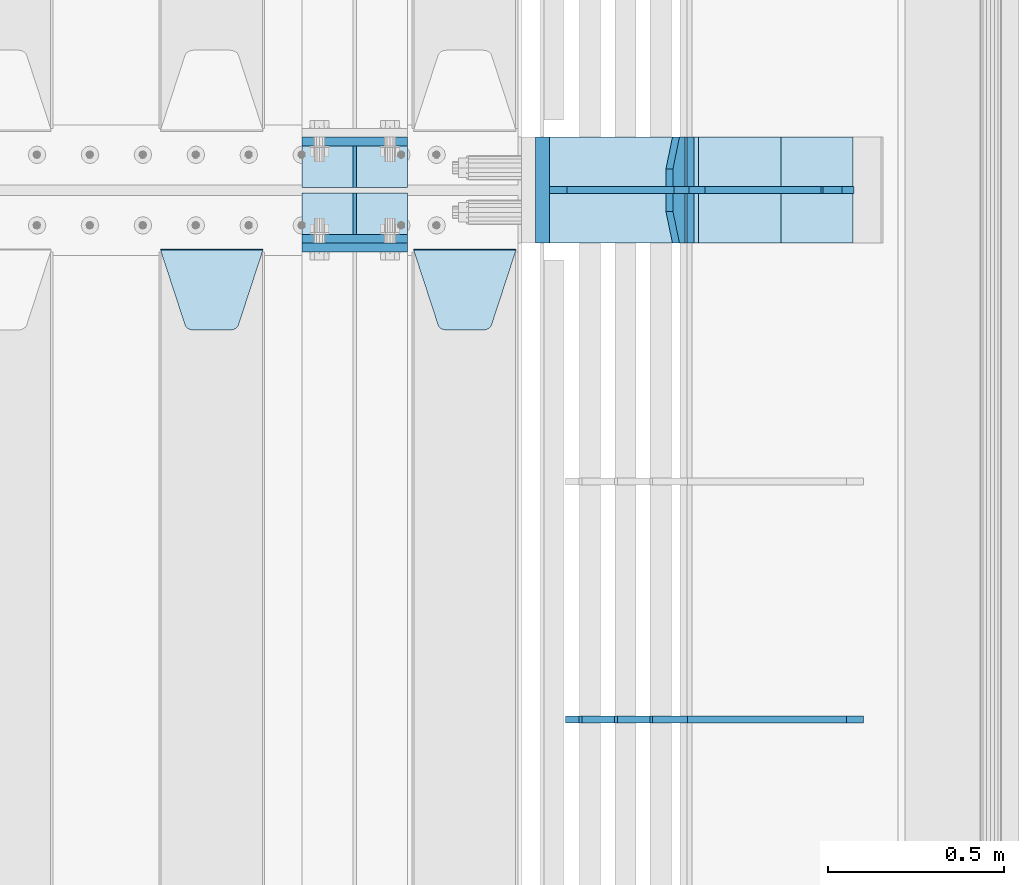
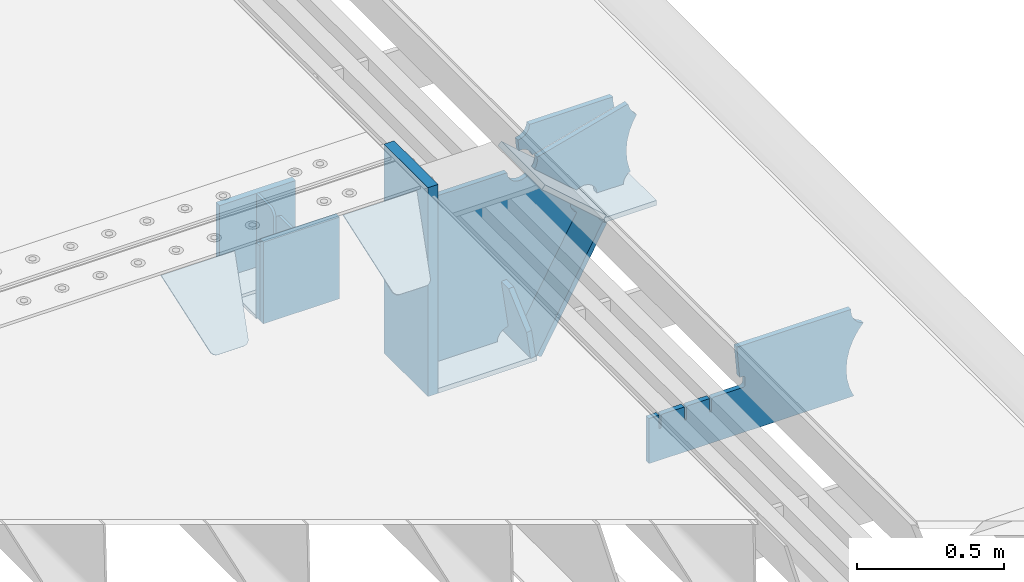
# One storey, part 203 of 240: 19 plates.
"""IFC2X3 building model written with IfcOpenShell, lengths in millimetres."""

from ifc_helpers import new_model, si_unit, frame, origin_with_axes, place, context, subcontext, project, spatial, faceted_brep, material, type_object, element, save


model = new_model("IFC2X3")

# Units and contexts
model_context = context("Model", 3, precision=1e-05, world=origin_with_axes())
body_context = subcontext(model_context, "Body", "Model", "MODEL_VIEW")
ifc_project = project(units=[si_unit("LENGTHUNIT", "METRE", prefix="MILLI"), si_unit("AREAUNIT", "SQUARE_METRE"), si_unit("VOLUMEUNIT", "CUBIC_METRE"), si_unit("MASSUNIT", "GRAM", prefix="KILO"), si_unit("TIMEUNIT", "SECOND"), si_unit("PLANEANGLEUNIT", "RADIAN"), si_unit("SOLIDANGLEUNIT", "STERADIAN"), si_unit("THERMODYNAMICTEMPERATUREUNIT", "DEGREE_CELSIUS"), si_unit("LUMINOUSINTENSITYUNIT", "LUMEN")], contexts=[model_context])

# Site, building, storey
site_placement = place(None, origin_with_axes())
site = spatial("IfcSite", under=ifc_project, at=site_placement, CompositionType="ELEMENT")
building_placement = place(site_placement, origin_with_axes())
building = spatial("IfcBuilding", under=site, at=building_placement, Name="Standard", CompositionType="ELEMENT")
storey_placement = place(building_placement, origin_with_axes())
storey = spatial("IfcBuildingStorey", under=building, at=storey_placement, Name="Undefined", CompositionType="ELEMENT", Elevation=0.0)

# Plates
ifc_material_1 = material(Name="STEEL/S355N")
plate_type_1 = type_object("IfcPlateType", PredefinedType="NOTDEFINED")
for number, where, z_axis, x_axis in (
    (1, (55855.0, 27137.5, -339.999999999995), (0.0, 0.0, 1.0), (1.0, 0.0, 0.0)),
    (2, (55855.0, 26862.5, -339.999999999995), (0.0, 0.0, 1.0), (1.0, 0.0, 0.0)),
):
    element("IfcPlate", number, at=place(storey_placement, frame(where, z_axis=z_axis, x_axis=x_axis)), inside=storey, type_object=plate_type_1, material=ifc_material_1, context=body_context, shape_type="Brep", body=[
        faceted_brep([(0.0, -12.5, 0.0), (0.0, -12.5, 310.0), (0.0, 12.5, 310.0), (0.0, 12.5, 0.0), (300.0, -12.5, 310.0), (300.0, 12.5, 310.0), (300.0, -12.5, 0.0), (300.0, 12.5, 0.0)], [[[0, 1, 2, 3]], [[1, 4, 5, 2]], [[4, 6, 7, 5]], [[6, 0, 3, 7]], [[5, 7, 3, 2]], [[6, 4, 1, 0]]]),
    ])
plate_1_placement = place(storey_placement, frame((55855.0, 26837.5, -340.000000000044), z_axis=(0.0, 0.0, 1.0), x_axis=(1.0, 0.0, 0.0)))
element("IfcPlate", 3, at=plate_1_placement, inside=storey, type_object=plate_type_1, material=ifc_material_1, context=body_context, shape_type="Brep", body=[
    faceted_brep([(0.0, -12.5, 0.0), (9.31322574615479e-10, -12.5, 340.0), (9.31322574615479e-10, 12.5, 340.0), (0.0, 12.5, 0.0), (300.0, -12.5, 340.0), (300.0, 12.5, 340.0), (300.0, -12.5, 0.0), (300.0, 12.5, 0.0)], [[[0, 1, 2, 3]], [[1, 4, 5, 2]], [[4, 6, 7, 5]], [[6, 0, 3, 7]], [[5, 7, 3, 2]], [[6, 4, 1, 0]]]),
])
plate_type_2 = type_object("IfcPlateType", PredefinedType="NOTDEFINED")
for number, where, z_axis, x_axis in (
    (4, (55855.0, 27008.0, -342.999999999995), (0.0, 1.0, 0.0), (1.0, 0.0, 0.0)),
    (5, (55855.0, 26992.0, -342.999999999995), (0.0, -1.0, 0.0), (1.0, 0.0, 0.0)),
):
    element("IfcPlate", number, at=place(storey_placement, frame(where, z_axis=z_axis, x_axis=x_axis)), inside=storey, type_object=plate_type_2, material=ifc_material_1, context=body_context, shape_type="Brep", body=[
        faceted_brep([(0.0, -7.0, 0.0), (0.0, -7.0, 117.0), (0.0, 7.0, 117.0), (0.0, 7.0, 0.0), (300.0, -7.0, 117.0), (300.0, 7.0, 117.0), (300.0, -7.0, 0.0), (300.0, 7.0, 0.0)], [[[0, 1, 2, 3]], [[1, 4, 5, 2]], [[4, 6, 7, 5]], [[6, 0, 3, 7]], [[5, 7, 3, 2]], [[6, 4, 1, 0]]]),
    ])
plate_type_3 = type_object("IfcPlateType", PredefinedType="NOTDEFINED")
for number, where, z_axis, x_axis in (
    (6, (56005.0, 27008.0, -29.9999999999945), (0.0, 0.0, -1.0), (0.0, 1.0, 0.0)),
    (7, (56005.0, 26992.0, -29.9999999999945), (0.0, 0.0, -1.0), (0.0, -1.0, 0.0)),
):
    element("IfcPlate", number, at=place(storey_placement, frame(where, z_axis=z_axis, x_axis=x_axis)), inside=storey, type_object=plate_type_3, material=ifc_material_1, context=body_context, shape_type="Brep", body=[
        faceted_brep([(0.0, -5.0, 30.0), (0.0, -5.0, 306.0), (0.0, 5.0, 306.0), (0.0, 5.0, 30.0), (117.0, -5.0, 306.0), (117.0, 5.0, 306.0), (117.0, -5.0, 0.0), (117.0, 5.0, 0.0), (30.0, -5.0, 0.0), (30.0, 5.0, 0.0), (24.7905546699913, -5.0, 0.455767409633758), (24.7905546699913, 5.0, 0.455767409633758), (19.7393957002278, -5.0, 1.80922137642275), (19.7393957002278, 5.0, 1.80922137642275), (15.0, -5.0, 4.01923788646684), (15.0, 5.0, 4.01923788646684), (10.7163717094008, -5.0, 7.01866670643066), (10.7163717094008, 5.0, 7.01866670643066), (7.01866670643358, -5.0, 10.7163717094038), (7.01866670643358, 5.0, 10.7163717094038), (4.01923788646673, -5.0, 15.0), (4.01923788646673, 5.0, 15.0), (1.80922137642483, -5.0, 19.7393957002299), (1.80922137642483, 5.0, 19.7393957002299), (0.455767409635882, -5.0, 24.7905546699921), (0.455767409635882, 5.0, 24.7905546699921)], [[[0, 1, 2, 3]], [[1, 4, 5, 2]], [[4, 6, 7, 5]], [[6, 8, 9, 7]], [[8, 10, 11, 9]], [[10, 12, 13, 11]], [[12, 14, 15, 13]], [[14, 16, 17, 15]], [[16, 18, 19, 17]], [[18, 20, 21, 19]], [[20, 22, 23, 21]], [[22, 24, 25, 23]], [[24, 0, 3, 25]], [[5, 7, 9, 11, 13, 15, 17, 19, 21, 23, 25, 3, 2]], [[24, 22, 20, 18, 16, 14, 12, 10, 8, 6, 4, 1, 0]]]),
    ])
plate_type_4 = type_object("IfcPlateType", PredefinedType="NOTDEFINED")
plate_2_placement = place(storey_placement, frame((56172.0, 26831.767766956, -1.76776695296758), z_axis=(0.0, -0.707106781186547, -0.707106781186548), x_axis=(1.0, 0.0, 0.0)))
element("IfcPlate", 8, at=plate_2_placement, inside=storey, type_object=plate_type_4, material=ifc_material_1, context=body_context, shape_type="Brep", body=[
    faceted_brep([(0.0, -2.5, 0.0), (69.345504679477, -2.50000000000364, 300.171731424827), (69.345504679477, 2.49999999999636, 300.171731424827), (0.0, 2.5, 0.0), (70.927406119954, -2.50000000000364, 304.897442415397), (70.927406119954, 2.49999999999636, 304.897442415397), (73.3818627772271, -2.50000000000728, 309.234538108525), (73.3818627772271, 2.49999999999636, 309.234538108529), (76.6187032999587, -2.50000000000728, 313.023683126099), (76.6187032999587, 2.49999999999636, 313.023683126103), (80.5190132705029, -2.50000000000364, 316.125672595368), (80.5190132705029, 2.49999999999636, 316.125672595368), (84.9395038596849, -2.50000000000364, 318.426546230472), (84.9395038596849, 2.49999999999636, 318.426546230472), (89.7177759439219, -2.5, 319.841774983277), (89.7177759439219, 2.49999999999636, 319.841774983273), (94.6782862926484, -2.50000000000364, 320.319366455074), (94.6782862926484, 2.49999999999636, 320.319366455074), (195.321713707352, -2.50000000000364, 320.319366455074), (195.321713707352, 2.49999999999636, 320.319366455074), (200.282224056078, -2.50000000000364, 319.841774983273), (200.282224056078, 2.49999999999636, 319.841774983273), (205.060496140315, -2.50000000000364, 318.426546230472), (205.060496140315, 2.49999999999636, 318.426546230472), (209.480986729497, -2.50000000000364, 316.125672595368), (209.480986729497, 2.49999999999636, 316.125672595368), (213.381296700041, -2.50000000000728, 313.023683126099), (213.381296700041, 2.49999999999272, 313.023683126099), (216.618137222766, -2.50000000000364, 309.234538108522), (216.618137222766, 2.49999999999636, 309.234538108522), (219.072593880039, -2.50000000000364, 304.897442415397), (219.072593880039, 2.49999999999636, 304.897442415397), (220.654495320523, -2.50000000000364, 300.171731424827), (220.654495320523, 2.49999999999636, 300.171731424827), (290.0, -2.50000000000364, -3.63797880709171e-12), (290.0, 2.49999999999636, -3.63797880709171e-12)], [[[0, 1, 2, 3]], [[1, 4, 5, 2]], [[4, 6, 7, 5]], [[6, 8, 9, 7]], [[8, 10, 11, 9]], [[10, 12, 13, 11]], [[12, 14, 15, 13]], [[14, 16, 17, 15]], [[16, 18, 19, 17]], [[18, 20, 21, 19]], [[20, 22, 23, 21]], [[22, 24, 25, 23]], [[24, 26, 27, 25]], [[26, 28, 29, 27]], [[28, 30, 31, 29]], [[30, 32, 33, 31]], [[32, 34, 35, 33]], [[34, 0, 3, 35]], [[5, 7, 9, 11, 13, 15, 17, 19, 21, 23, 25, 27, 29, 31, 33, 35, 3, 2]], [[34, 32, 30, 28, 26, 24, 22, 20, 18, 16, 14, 12, 10, 8, 6, 4, 1, 0]]]),
])
plate_3_placement = place(storey_placement, frame((55455.0, 26831.767766956, -1.76776695296758), z_axis=(0.0, -0.707106781186547, -0.707106781186548), x_axis=(1.0, 0.0, 0.0)))
element("IfcPlate", 9, at=plate_3_placement, inside=storey, type_object=plate_type_4, material=ifc_material_1, context=body_context, shape_type="Brep", body=[
    faceted_brep([(0.0, -2.5, 0.0), (69.345504679477, -2.50000000000364, 300.171731424827), (69.345504679477, 2.49999999999636, 300.171731424827), (0.0, 2.5, 0.0), (70.927406119954, -2.50000000000364, 304.897442415397), (70.927406119954, 2.49999999999636, 304.897442415397), (73.3818627772271, -2.50000000000728, 309.234538108525), (73.3818627772271, 2.49999999999636, 309.234538108529), (76.6187032999587, -2.50000000000728, 313.023683126099), (76.6187032999587, 2.49999999999636, 313.023683126103), (80.5190132705029, -2.50000000000364, 316.125672595368), (80.5190132705029, 2.49999999999636, 316.125672595368), (84.9395038596849, -2.50000000000364, 318.426546230472), (84.9395038596849, 2.49999999999636, 318.426546230472), (89.7177759439219, -2.5, 319.841774983277), (89.7177759439219, 2.49999999999636, 319.841774983273), (94.6782862926484, -2.50000000000364, 320.319366455074), (94.6782862926484, 2.49999999999636, 320.319366455074), (195.321713707352, -2.50000000000364, 320.319366455074), (195.321713707352, 2.49999999999636, 320.319366455074), (200.282224056078, -2.50000000000364, 319.841774983273), (200.282224056078, 2.49999999999636, 319.841774983273), (205.060496140315, -2.50000000000364, 318.426546230472), (205.060496140315, 2.49999999999636, 318.426546230472), (209.480986729497, -2.50000000000364, 316.125672595368), (209.480986729497, 2.49999999999636, 316.125672595368), (213.381296700041, -2.50000000000728, 313.023683126099), (213.381296700041, 2.49999999999272, 313.023683126099), (216.618137222766, -2.50000000000364, 309.234538108522), (216.618137222766, 2.49999999999636, 309.234538108522), (219.072593880039, -2.50000000000364, 304.897442415397), (219.072593880039, 2.49999999999636, 304.897442415397), (220.654495320523, -2.50000000000364, 300.171731424827), (220.654495320523, 2.49999999999636, 300.171731424827), (290.0, -2.50000000000364, -3.63797880709171e-12), (290.0, 2.49999999999636, -3.63797880709171e-12)], [[[0, 1, 2, 3]], [[1, 4, 5, 2]], [[4, 6, 7, 5]], [[6, 8, 9, 7]], [[8, 10, 11, 9]], [[10, 12, 13, 11]], [[12, 14, 15, 13]], [[14, 16, 17, 15]], [[16, 18, 19, 17]], [[18, 20, 21, 19]], [[20, 22, 23, 21]], [[22, 24, 25, 23]], [[24, 26, 27, 25]], [[26, 28, 29, 27]], [[28, 30, 31, 29]], [[30, 32, 33, 31]], [[32, 34, 35, 33]], [[34, 0, 3, 35]], [[5, 7, 9, 11, 13, 15, 17, 19, 21, 23, 25, 27, 29, 31, 33, 35, 3, 2]], [[34, 32, 30, 28, 26, 24, 22, 20, 18, 16, 14, 12, 10, 8, 6, 4, 1, 0]]]),
])
plate_type_5 = type_object("IfcPlateType", PredefinedType="NOTDEFINED")
plate_4_placement = place(storey_placement, frame((56931.0775331948, 27150.0000000017, -871.412303810021), z_axis=(0.0, -1.0, 0.0), x_axis=(-0.137902988002476, 0.0, 0.990445741017643)))
element("IfcPlate", 10, at=plate_4_placement, inside=storey, type_object=plate_type_5, material=ifc_material_1, context=body_context, shape_type="Brep", body=[
    faceted_brep([(0.0, -10.0, 0.0), (-1.98269844986498e-10, -10.0, 300.0), (-1.98269844986498e-10, 10.0, 300.0), (0.0, 10.0, 0.0), (115.0, -10.0, 300.0), (115.0, 10.0, 300.0), (250.0, -10.0, 210.0), (250.0, 10.0, 210.0), (250.0, -10.0, 90.0), (250.0, 10.0, 90.0), (115.0, -10.0, -1.09139364212751e-10), (115.0, 10.0, -1.09139364212751e-10)], [[[0, 1, 2, 3]], [[1, 4, 5, 2]], [[4, 6, 7, 5]], [[6, 8, 9, 7]], [[8, 10, 11, 9]], [[10, 0, 3, 11]], [[5, 7, 9, 11, 3, 2]], [[10, 8, 6, 4, 1, 0]]]),
])
plate_type_6 = type_object("IfcPlateType", PredefinedType="NOTDEFINED")
plate_5_placement = place(storey_placement, frame((56959.9988298915, 27000.0000000001, -179.999999999866), z_axis=(0.0, 0.0, -1.0), x_axis=(-1.0, 0.0, 0.0)))
element("IfcPlate", 11, at=plate_5_placement, inside=storey, type_object=plate_type_6, material=ifc_material_1, context=body_context, shape_type="Brep", body=[
    faceted_brep([(46.0258547361809, 10.0, 641.078828352491), (73.3015011075258, 10.0000000000146, 445.179898435806), (73.3015011075258, -9.99999999998545, 445.179898435806), (46.0258547361809, -10.0, 641.078828352491), (53.4925862871751, 10.0000000000146, 442.421838675757), (53.4925862871751, -9.99999999998545, 442.421838675757), (25.782050112437, 10.0, 641.444230671302), (25.782050112437, -10.0, 641.444230671302), (54.6652503111691, 10.0, 642.447174185377), (54.6652503111691, -10.0, 642.447174185377), (68.6036632070463, -10.0, 649.549150281387), (68.6036632070463, 10.0, 649.549150281387), (79.6652503111691, -10.0, 660.610737385511), (79.6652503111691, 10.0, 660.610737385511), (86.7672264071807, -10.0, 674.549150281387), (86.7672264071807, 10.0, 674.549150281387), (89.2144005924201, -10.0, 690.0), (89.2144005924201, 10.0, 690.0), (353.0, -10.0, 690.0), (353.0, 10.0, 690.0), (355.447174185239, -10.0, 674.549150281253), (355.447174185239, 10.0, 674.549150281253), (362.549150281251, -10.0, 660.610737385376), (362.549150281251, 10.0, 660.610737385376), (373.610737385374, -10.0, 649.549150281253), (373.610737385374, 10.0, 649.549150281253), (387.549150281251, -10.0, 642.447174185242), (387.549150281251, 10.0, 642.447174185242), (403.0, -10.0, 640.0), (403.0, 10.0, 640.0), (403.0, -10.0, 50.0), (403.0, 10.0, 50.0), (387.549150281251, -10.0, 47.5528258147577), (387.549150281251, 10.0, 47.5528258147577), (373.610737385374, -10.0, 40.4508497187474), (373.610737385374, 10.0, 40.4508497187474), (362.549150281251, -10.0, 29.3892626146236), (362.549150281251, 10.0, 29.3892626146236), (355.447174185239, -10.0, 15.4508497187474), (355.447174185239, 10.0, 15.4508497187474), (353.0, -10.0, 0.0), (353.0, 10.0, 0.0), (50.0, -10.0, 0.0), (50.0, 10.0, 0.0), (47.0349915316328, -10.0, 16.9620037619133), (47.0349915316328, 10.0, 16.9620037619133), (38.4916171352306, -10.0, 31.9123081320451), (38.4916171352306, 10.0, 31.9123081320451), (25.3831239081483, -10.0, 43.0778019479116), (25.3831239081483, 10.0, 43.0778019479116), (9.26418358741648, -10.0, 49.1342538608113), (9.26418358741648, 10.0, 49.1342538608113), (-7.95349204488593, -10.0, 49.363366622344), (-7.95349204488593, 10.0, 49.363366622344), (-24.2278808265401, -10.0, 43.7379673813837), (-24.2278808265401, 10.0, 43.7379673813837), (-37.6288347353475, -10.0, 32.9252303934259), (-37.6288347353475, 10.0, 32.9252303934259), (-210.371165264653, -10.0, 184.074769606574), (-210.371165264653, 10.0, 184.074769606574), (-202.382363280565, -10.0, 196.529747922069), (-202.382363280565, 10.0, 196.529747922069), (-198.388707244048, -10.0, 210.777489969227), (-198.388707244048, 10.0, 210.777489969227), (-198.73995746443, -10.0, 225.570193077959), (-198.73995746443, 10.0, 225.570193077959), (-203.40535180681, -10.0, 239.612327446012), (-203.40535180681, 10.0, 239.612327446012), (-211.976299808361, -10.0, 251.674097313455), (-211.976299808361, 10.0, 251.674097313455), (-223.702166612966, -10.0, 260.699145216992), (-223.702166612966, 10.0, 260.699145216992), (-9.29783338703419, -10.0, 646.300854783008), (-9.29783338703419, 10.0, 646.300854783008), (6.98069453598146, -10.0, 640.647282345602), (6.98069453598146, 10.0, 640.647282345602), (24.2117663163663, -10.0, 640.855891896051), (24.2117663163663, 10.0, 640.855891896051)], [[[0, 1, 2, 3]], [[4, 5, 2, 1]], [[6, 7, 5, 4]], [[8, 9, 10, 11]], [[11, 10, 12, 13]], [[13, 12, 14, 15]], [[15, 14, 16, 17]], [[18, 19, 17, 16]], [[18, 20, 21, 19]], [[20, 22, 23, 21]], [[22, 24, 25, 23]], [[24, 26, 27, 25]], [[26, 28, 29, 27]], [[28, 30, 31, 29]], [[30, 32, 33, 31]], [[32, 34, 35, 33]], [[34, 36, 37, 35]], [[36, 38, 39, 37]], [[38, 40, 41, 39]], [[40, 42, 43, 41]], [[42, 44, 45, 43]], [[44, 46, 47, 45]], [[46, 48, 49, 47]], [[48, 50, 51, 49]], [[50, 52, 53, 51]], [[52, 54, 55, 53]], [[54, 56, 57, 55]], [[56, 58, 59, 57]], [[58, 60, 61, 59]], [[60, 62, 63, 61]], [[62, 64, 65, 63]], [[64, 66, 67, 65]], [[66, 68, 69, 67]], [[68, 70, 71, 69]], [[70, 72, 73, 71]], [[72, 74, 75, 73]], [[74, 76, 77, 75]], [[1, 0, 8, 11, 13, 15, 17, 19, 21, 23, 25, 27, 29, 31, 33, 35, 37, 39, 41, 43, 45, 47, 49, 51, 53, 55, 57, 59, 61, 63, 65, 67, 69, 71, 73, 75, 77, 6, 4]], [[9, 8, 0, 3]], [[76, 74, 72, 70, 68, 66, 64, 62, 60, 58, 56, 54, 52, 50, 48, 46, 44, 42, 40, 38, 36, 34, 32, 30, 28, 26, 24, 22, 20, 18, 16, 14, 12, 10, 9, 3, 2, 5, 7]], [[77, 76, 7, 6]]]),
])
plate_type_7 = type_object("IfcPlateType", PredefinedType="NOTDEFINED")
plate_6_placement = place(storey_placement, frame((57500.9988502514, 26999.9999999993, -28.9999913318487), z_axis=(0.260769276985653, 0.0, -0.965401151946889), x_axis=(-0.965401151946889, 0.0, -0.260769276985654)))
element("IfcPlate", 12, at=plate_6_placement, inside=storey, type_object=plate_type_7, material=ifc_material_1, context=body_context, shape_type="Brep", body=[
    faceted_brep([(183.436474692309, 10.0, 275.852500330424), (184.91838860904, 10.0, 264.41784353133), (184.91838860904, -10.0, 264.41784353133), (183.436474692309, -10.0, 275.852500330424), (183.794583267605, 10.0, 224.576469334612), (183.794583267605, -10.0, 224.576469334612), (176.45204977582, 10.0, 185.401410454628), (176.45204977582, -10.0, 185.401410454628), (163.071585676764, 10.0, 147.857286855562), (163.071585676764, -10.0, 147.857286855562), (143.982662403731, 10.0, 112.868559462233), (143.982662403731, -10.0, 112.868559462233), (119.655312600233, 10.0, 81.2967668639885), (119.655312600233, -10.0, 81.2967668639885), (100.960891712748, 10.0, 63.6280409830943), (100.960891712748, -10.0, 63.6280409830943), (194.486836975891, -10.0, 278.751956446691), (207.178624553366, -10.0, 286.650994937518), (207.178624553366, 10.0, 286.650994937518), (194.486836975891, 10.0, 278.751956446691), (216.968013469435, -10.0, 297.948965801399), (216.968013469435, 10.0, 297.948965801399), (222.979925232852, -10.0, 311.635937633771), (222.979925232852, 10.0, 311.635937633771), (323.381647032758, -10.0, 284.515917834986), (323.381647032758, 10.0, 284.515917834986), (321.720617177329, -10.0, 268.853198956864), (321.720617177329, 10.0, 268.853198956864), (325.014344481133, -10.0, 253.450889283185), (325.014344481133, 10.0, 253.450889283185), (332.935986082477, -10.0, 239.837389469556), (332.935986082477, 10.0, 239.837389469556), (344.699462330085, -10.0, 229.363593146938), (344.699462330085, 10.0, 229.363593146938), (359.1374609708, -10.0, 223.068835162203), (359.1374609708, 10.0, 223.068835162203), (374.817271777676, -10.0, 221.577756392893), (374.817271777676, 10.0, 221.577756392893), (390.182952880852, -10.0, 225.03833007813), (390.182952880852, 10.0, 225.03833007813), (512.909060513019, -10.0, 41.5599003357038), (512.909060513019, 10.0, 41.5599003357038), (503.648024844573, -10.0, 33.564366674771), (503.648024844573, 10.0, 33.564366674771), (496.6060645697, -10.0, 23.5590612990018), (496.6060645697, 10.0, 23.5590612990018), (492.204839143924, -10.0, 12.1430832451115), (492.204839143924, 10.0, 12.1430832451115), (490.707885742188, -10.0, 3.8198777474463e-10), (490.707885742188, 10.0, 3.8198777474463e-10), (119.999999999993, -10.0, 9.64064383879304e-11), (119.999999999993, 10.0, 9.64064383879304e-11), (117.226254779103, -10.0, 25.6516118492182), (117.226254779103, 10.0, 25.6516118492182), (109.033246825653, -10.0, 50.1173731021008), (109.033246825653, 10.0, 50.1173731021008)], [[[0, 1, 2, 3]], [[4, 5, 2, 1]], [[6, 7, 5, 4]], [[8, 9, 7, 6]], [[10, 11, 9, 8]], [[12, 13, 11, 10]], [[14, 15, 13, 12]], [[16, 17, 18, 19]], [[17, 20, 21, 18]], [[20, 22, 23, 21]], [[22, 24, 25, 23]], [[24, 26, 27, 25]], [[26, 28, 29, 27]], [[28, 30, 31, 29]], [[30, 32, 33, 31]], [[32, 34, 35, 33]], [[34, 36, 37, 35]], [[36, 38, 39, 37]], [[38, 40, 41, 39]], [[40, 42, 43, 41]], [[42, 44, 45, 43]], [[44, 46, 47, 45]], [[46, 48, 49, 47]], [[48, 50, 51, 49]], [[50, 52, 53, 51]], [[52, 54, 55, 53]], [[10, 8, 6, 4, 1, 0, 19, 18, 21, 23, 25, 27, 29, 31, 33, 35, 37, 39, 41, 43, 45, 47, 49, 51, 53, 55, 14, 12]], [[16, 19, 0, 3]], [[54, 52, 50, 48, 46, 44, 42, 40, 38, 36, 34, 32, 30, 28, 26, 24, 22, 20, 17, 16, 3, 2, 5, 7, 9, 11, 13, 15]], [[55, 54, 15, 14]]]),
])
plate_type_8 = type_object("IfcPlateType", PredefinedType="NOTDEFINED")
plate_7_placement = place(storey_placement, frame((56972.2260590444, 27149.9999999993, -177.219372761326), z_axis=(0.752414935148685, 0.0, -0.658689430130164), x_axis=(0.0, -1.0, 0.0)))
element("IfcPlate", 13, at=plate_7_placement, inside=storey, type_object=plate_type_8, material=ifc_material_1, context=body_context, shape_type="Brep", body=[
    faceted_brep([(0.0, -10.0, 0.0), (1.09139364212751e-10, -10.0000000000073, 319.999999999993), (1.09139364212751e-10, 10.0, 319.999999999993), (0.0, 10.0, 0.0), (300.0, -10.0000000000073, 319.999999999993), (300.0, 10.0, 319.999999999993), (300.0, -10.0, 5.82076609134674e-11), (300.0, 10.0, 5.82076609134674e-11)], [[[0, 1, 2, 3]], [[1, 4, 5, 2]], [[4, 6, 7, 5]], [[6, 0, 3, 7]], [[5, 7, 3, 2]], [[6, 4, 1, 0]]]),
])
plate_8_placement = place(storey_placement, frame((57213.000728811, 27150.0000000001, -408.004820491625), z_axis=(-0.484064236150485, 0.0, -0.875032465272031), x_axis=(0.0, -1.0, 0.0)))
element("IfcPlate", 14, at=plate_8_placement, inside=storey, type_object=plate_type_8, material=ifc_material_1, context=body_context, shape_type="Brep", body=[
    faceted_brep([(0.0, -10.0, 0.0), (3.86513420380652e-07, -10.0, 533.528442382813), (3.86513420380652e-07, 9.99999999999272, 533.528442382809), (0.0, 10.0, 0.0), (300.003295898438, -10.0000000000073, 533.549133300778), (300.003295898438, 10.0, 533.549133300781), (300.0, -10.0, 5.82076609134674e-11), (300.0, 10.0, 5.82076609134674e-11)], [[[0, 1, 2, 3]], [[1, 4, 5, 2]], [[4, 6, 7, 5]], [[6, 0, 3, 7]], [[5, 7, 3, 2]], [[6, 4, 1, 0]]]),
])
plate_9_placement = place(storey_placement, frame((56556.9988298915, 27150.0000000001, -879.999999999866), z_axis=(0.0, -1.0, 0.0), x_axis=(1.0, 0.0, 0.0)))
element("IfcPlate", 15, at=plate_9_placement, inside=storey, type_object=plate_type_8, material=ifc_material_1, context=body_context, shape_type="Brep", body=[
    faceted_brep([(0.0, -10.0, 0.0), (-1.98269844986498e-10, -10.0, 300.0), (-1.98269844986498e-10, 10.0, 300.0), (0.0, 10.0, 0.0), (389.0, -10.0, 300.0), (389.0, 10.0, 300.0), (389.0, -10.0, 0.0), (389.0, 10.0, 0.0)], [[[0, 1, 2, 3]], [[1, 4, 5, 2]], [[4, 6, 7, 5]], [[6, 0, 3, 7]], [[5, 7, 3, 2]], [[6, 4, 1, 0]]]),
])
plate_type_9 = type_object("IfcPlateType", PredefinedType="NOTDEFINED")
plate_10_placement = place(storey_placement, frame((57416.9988298915, 27149.9999999993, -397.999999999763), z_axis=(-1.0, 0.0, 0.0), x_axis=(0.0, -1.0, 0.0)))
element("IfcPlate", 16, at=plate_10_placement, inside=storey, type_object=plate_type_9, material=ifc_material_1, context=body_context, shape_type="Brep", body=[
    faceted_brep([(0.0, -10.0, 0.0), (4.65661287307739e-10, -10.0, 204.0), (4.65661287307739e-10, 10.0, 204.0), (0.0, 10.0, 0.0), (300.0, -10.0, 204.0), (300.0, 10.0, 204.0), (300.0, -10.0, 5.82076609134674e-11), (300.0, 10.0, 5.82076609134674e-11)], [[[0, 1, 2, 3]], [[1, 4, 5, 2]], [[4, 6, 7, 5]], [[6, 0, 3, 7]], [[5, 7, 3, 2]], [[6, 4, 1, 0]]]),
])
ifc_material_2 = material()
plate_type_10 = type_object("IfcPlateType", PredefinedType="NOTDEFINED")
plate_11_placement = place(storey_placement, frame((56536.9988298908, 27150.0, -889.999999999995), z_axis=(0.0, 0.0, 1.0), x_axis=(0.0, -1.0, 0.0)))
element("IfcPlate", 17, at=plate_11_placement, inside=storey, type_object=plate_type_10, material=ifc_material_2, context=body_context, shape_type="Brep", body=[
    faceted_brep([(0.0, -20.0, 0.0), (0.0, -20.0, 870.0), (0.0, 20.0, 870.0), (0.0, 20.0, 0.0), (300.0, -20.0, 870.0), (300.0, 20.0, 870.0), (300.0, -20.0, -1.81898940354586e-12), (300.0, 20.0, -1.81898940354586e-12)], [[[0, 1, 2, 3]], [[1, 4, 5, 2]], [[4, 6, 7, 5]], [[6, 0, 3, 7]], [[5, 7, 3, 2]], [[6, 4, 1, 0]]]),
])
plate_type_11 = type_object("IfcPlateType", PredefinedType="NOTDEFINED")
plate_12_placement = place(storey_placement, frame((57495.9988298907, 27000.0, -9.99999999999716), z_axis=(0.0, 0.0, -1.0), x_axis=(-1.0, 0.0, 0.0)))
element("IfcPlate", 18, at=plate_12_placement, inside=storey, type_object=plate_type_11, material=ifc_material_1, context=body_context, shape_type="Brep", body=[
    faceted_brep([(164.157641141064, -10.0, 44.1844865875018), (486.71834084086, -10.0, 131.004562768382), (486.71834084086, 10.0, 131.004562768382), (164.157641141064, 10.0, 44.1844865875018), (492.179177700767, -10.0, 118.185717565315), (492.179177700767, 10.0, 118.185717565315), (500.965368826706, -10.0, 107.371542744776), (500.965368826706, 10.0, 107.371542744776), (512.394601349042, -10.0, 99.4018391429503), (512.394601349042, 10.0, 99.4018391429503), (525.579310641864, -10.0, 94.8955133209048), (525.579310641864, 10.0, 94.8955133209048), (539.495606295335, -10.0, 94.2025148824028), (539.495606295335, 10.0, 94.2025148824028), (543.504393704665, -10.0, 49.7974851175972), (543.504393704665, 10.0, 49.7974851175972), (529.167086307512, -10.0, 46.3176139481669), (529.167086307512, 10.0, 46.3176139481669), (516.469507120331, -10.0, 38.8049999196639), (516.469507120331, 10.0, 38.8049999196639), (506.517198234542, -10.0, 27.9137449599276), (506.517198234542, 10.0, 27.9137449599276), (500.17667886756, -10.0, 14.592119649441), (500.17667886756, 10.0, 14.592119649441), (498.0, -10.0, 0.0), (498.0, 10.0, 0.0), (170.0, -10.0, 0.0), (170.0, 10.0, 0.0), (169.632873911985, -10.0, 11.1663820622718), (169.632873911985, 10.0, 11.1663820622718), (168.533081313406, -10.0, 22.2845350637931), (168.533081313406, 10.0, 22.2845350637931), (166.705372351957, -10.0, 33.3064382514178), (166.705372351957, 10.0, 33.3064382514178)], [[[0, 1, 2, 3]], [[1, 4, 5, 2]], [[4, 6, 7, 5]], [[6, 8, 9, 7]], [[8, 10, 11, 9]], [[10, 12, 13, 11]], [[12, 14, 15, 13]], [[14, 16, 17, 15]], [[16, 18, 19, 17]], [[18, 20, 21, 19]], [[20, 22, 23, 21]], [[22, 24, 25, 23]], [[24, 26, 27, 25]], [[26, 28, 29, 27]], [[28, 30, 31, 29]], [[30, 32, 33, 31]], [[32, 0, 3, 33]], [[5, 7, 9, 11, 13, 15, 17, 19, 21, 23, 25, 27, 29, 31, 33, 3, 2]], [[32, 30, 28, 26, 24, 22, 20, 18, 16, 14, 12, 10, 8, 6, 4, 1, 0]]]),
])
plate_type_12 = type_object("IfcPlateType", PredefinedType="NOTDEFINED")
plate_13_placement = place(storey_placement, frame((57442.9182339676, 25499.9992828369, -374.002067436518), z_axis=(0.0, 0.0, 1.0), x_axis=(-1.0, 0.0, 0.0)))
element("IfcPlate", 19, at=plate_13_placement, inside=storey, type_object=plate_type_12, material=ifc_material_1, context=body_context, shape_type="Brep", body=[
    faceted_brep([(801.919404066546, -10.0, 188.0), (801.919404066546, 10.0, 188.0), (801.919404066546, 10.0, 132.002067436952), (801.919404066546, -10.0, 132.002067436952), (793.919404066546, 10.0, 132.002067436952), (793.919404066546, -10.0, 132.002067436952), (793.919404066546, 10.0, 180.002067436952), (793.919404066546, -10.0, 180.002067436952), (793.52785619691, 10.0, 182.474203391951), (793.52785619691, -10.0, 182.474203391951), (792.391540021548, 10.0, 184.704349455291), (792.391540021548, -10.0, 184.704349455291), (790.621686084887, 10.0, 186.474203391951), (790.621686084887, -10.0, 186.474203391951), (788.391540021548, 10.0, 187.610519567313), (788.391540021548, -10.0, 187.610519567313), (785.919404066546, -10.0, 188.002067436952), (785.919404066546, 10.0, 188.0), (841.0, -10.0, 188.0), (841.0, -10.0, 0.0), (841.0, 10.0, 0.0), (841.0, 10.0, 188.0), (33.3619566735943, -10.0, 0.0), (33.3619566735943, 10.0, 0.0), (36.2350612208102, -10.0, 4.68848050267013), (36.2350612208102, 10.0, 4.68848050267013), (51.4877592159319, -10.0, 41.5117508652784), (51.4877592159319, 10.0, 41.5117508652784), (60.7922425881334, -10.0, 80.2677133162964), (60.7922425881334, 10.0, 80.2677133162964), (63.9194040769653, -10.0, 120.002067436515), (63.9194040769653, 10.0, 120.002067436515), (60.7922425881334, -10.0, 159.736421556734), (60.7922425881334, 10.0, 159.736421556734), (51.4877592159319, -10.0, 198.492384007752), (51.4877592159319, 10.0, 198.492384007752), (36.2350612208102, -10.0, 235.31565437036), (36.2350612208102, 10.0, 235.31565437036), (15.4097206482038, -10.0, 269.299521518803), (15.4097206482038, 10.0, 269.299521518803), (-3.35474438100209, -10.0, 291.269887256574), (-3.35474438100209, 10.0, 291.269887256574), (-2.36881039375294, -10.0000000000036, 291.426043859339), (-2.36881039375294, 10.0, 291.426043859339), (17.1449676604752, -10.0000000000036, 301.368810393754), (17.1449676604752, 10.0, 301.368810393754), (32.6311896062471, -10.0000000000036, 316.855032339527), (32.6311896062471, 10.0, 316.855032339527), (42.573956140659, -10.0000000000036, 336.368810393754), (42.573956140659, 10.0, 336.368810393754), (46.0, -10.0000000000036, 358.0), (46.0, 10.0, 358.0), (45.0495205499246, -10.0, 364.001091067617), (45.0495205499246, 10.0, 364.001091067617), (495.040008544922, -10.0, 364.010009765625), (495.040008544922, 10.0, 364.010009765625), (483.600036621094, -10.0, 233.759994506836), (483.600036621094, 10.0, 233.759994506836), (472.0, -10.0, 233.759994506836), (472.0, 10.0, 233.759994506836), (468.909830056247, -10.0, 233.270559669787), (468.909830056247, 10.0, 233.270559669787), (466.122147477072, -10.0, 231.850164450585), (466.122147477072, 10.0, 231.850164450585), (463.909830056247, -10.0, 229.637847029761), (463.909830056247, 10.0, 229.637847029761), (462.489434837051, -10.0, 226.850164450585), (462.489434837051, 10.0, 226.850164450585), (462.0, -10.0, 223.759994506836), (462.0, 10.0, 223.759994506836), (462.0, -10.0, 198.0), (462.0, 10.0, 198.0), (462.489434837051, -10.0, 194.909830056251), (462.489434837051, 10.0, 194.909830056251), (463.909830056247, -10.0, 192.122147477075), (463.909830056247, 10.0, 192.122147477075), (466.122147477072, -10.0, 189.909830056251), (466.122147477072, 10.0, 189.909830056251), (468.909830056247, -10.0, 188.489434837048), (468.909830056247, 10.0, 188.489434837048), (472.0, -10.0, 188.0), (472.0, 10.0, 188.0), (585.919404066546, -10.0, 188.002067436952), (585.919404066546, 10.0, 188.0), (588.391540021548, -9.99999999999636, 187.610519567313), (588.391540021548, 10.0, 187.610519567313), (590.621686084887, -9.99999999999636, 186.474203391951), (590.621686084887, 10.0, 186.474203391951), (592.391540021548, -9.99999999999636, 184.704349455291), (592.391540021548, 10.0, 184.704349455291), (593.52785619691, -9.99999999999636, 182.474203391951), (593.52785619691, 10.0, 182.474203391951), (593.919404066546, -9.99999999999636, 180.002067436952), (593.919404066546, 10.0, 180.002067436952), (593.919404066546, -9.99999999999636, 132.002067436952), (593.919404066546, 10.0, 132.002067436952), (601.919404066546, -9.99999999999636, 132.002067436952), (601.919404066546, 10.0, 132.002067436952), (601.919404066546, -10.0, 188.0), (601.919404066546, 10.0, 188.0), (685.919404066546, -10.0, 188.002067436952), (685.919404066546, 10.0, 188.0), (688.391540021548, -10.0, 187.610519567313), (688.391540021548, 10.0, 187.610519567313), (690.621686084887, -10.0, 186.474203391951), (690.621686084887, 10.0, 186.474203391951), (692.391540021548, -10.0, 184.704349455291), (692.391540021548, 10.0, 184.704349455291), (693.52785619691, -10.0, 182.474203391951), (693.52785619691, 10.0, 182.474203391951), (693.919404066546, -10.0, 180.002067436952), (693.919404066546, 10.0, 180.002067436952), (693.919404066546, -10.0, 132.002067436952), (693.919404066546, 10.0000000000036, 132.002067436952), (701.919404066546, -10.0, 132.002067436952), (701.919404066546, 10.0000000000036, 132.002067436952), (701.919404066546, -10.0, 188.0), (701.919404066546, 10.0, 188.0)], [[[0, 1, 2, 3]], [[3, 2, 4, 5]], [[5, 4, 6, 7]], [[7, 6, 8, 9]], [[9, 8, 10, 11]], [[11, 10, 12, 13]], [[13, 12, 14, 15]], [[16, 15, 14, 17]], [[18, 19, 20, 21]], [[20, 19, 22, 23]], [[22, 24, 25, 23]], [[26, 27, 25, 24]], [[28, 29, 27, 26]], [[30, 31, 29, 28]], [[32, 33, 31, 30]], [[34, 35, 33, 32]], [[36, 37, 35, 34]], [[38, 39, 37, 36]], [[39, 38, 40, 41]], [[40, 42, 43, 41]], [[44, 45, 43, 42]], [[46, 47, 45, 44]], [[48, 49, 47, 46]], [[50, 51, 49, 48]], [[52, 53, 51, 50]], [[54, 55, 53, 52]], [[54, 56, 57, 55]], [[56, 58, 59, 57]], [[58, 60, 61, 59]], [[60, 62, 63, 61]], [[62, 64, 65, 63]], [[64, 66, 67, 65]], [[66, 68, 69, 67]], [[68, 70, 71, 69]], [[70, 72, 73, 71]], [[72, 74, 75, 73]], [[74, 76, 77, 75]], [[76, 78, 79, 77]], [[78, 80, 81, 79]], [[81, 80, 82, 83]], [[82, 84, 85, 83]], [[86, 87, 85, 84]], [[88, 89, 87, 86]], [[90, 91, 89, 88]], [[92, 93, 91, 90]], [[94, 95, 93, 92]], [[96, 97, 95, 94]], [[98, 99, 97, 96]], [[99, 98, 100, 101]], [[100, 102, 103, 101]], [[104, 105, 103, 102]], [[106, 107, 105, 104]], [[108, 109, 107, 106]], [[110, 111, 109, 108]], [[112, 113, 111, 110]], [[114, 115, 113, 112]], [[116, 117, 115, 114]], [[117, 116, 16, 17]], [[12, 10, 8, 6, 4, 2, 1, 21, 20, 23, 25, 27, 29, 31, 33, 35, 37, 39, 41, 43, 45, 47, 49, 51, 53, 55, 57, 59, 61, 63, 65, 67, 69, 71, 73, 75, 77, 79, 81, 83, 85, 87, 89, 91, 93, 95, 97, 99, 101, 103, 105, 107, 109, 111, 113, 115, 117, 17, 14]], [[18, 21, 1, 0]], [[116, 114, 112, 110, 108, 106, 104, 102, 100, 98, 96, 94, 92, 90, 88, 86, 84, 82, 80, 78, 76, 74, 72, 70, 68, 66, 64, 62, 60, 58, 56, 54, 52, 50, 48, 46, 44, 42, 40, 38, 36, 34, 32, 30, 28, 26, 24, 22, 19, 18, 0, 3, 5, 7, 9, 11, 13, 15, 16]]]),
])

save(model, "model.ifc")
